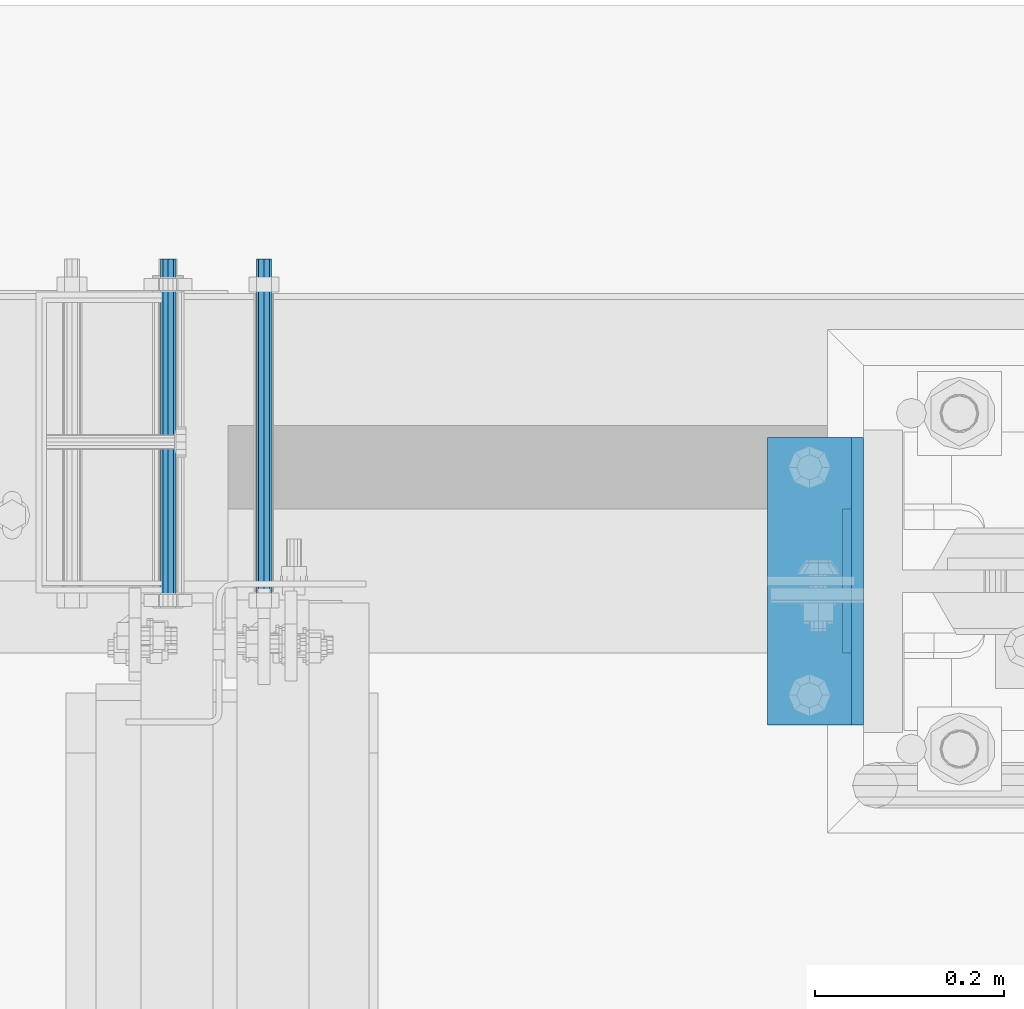
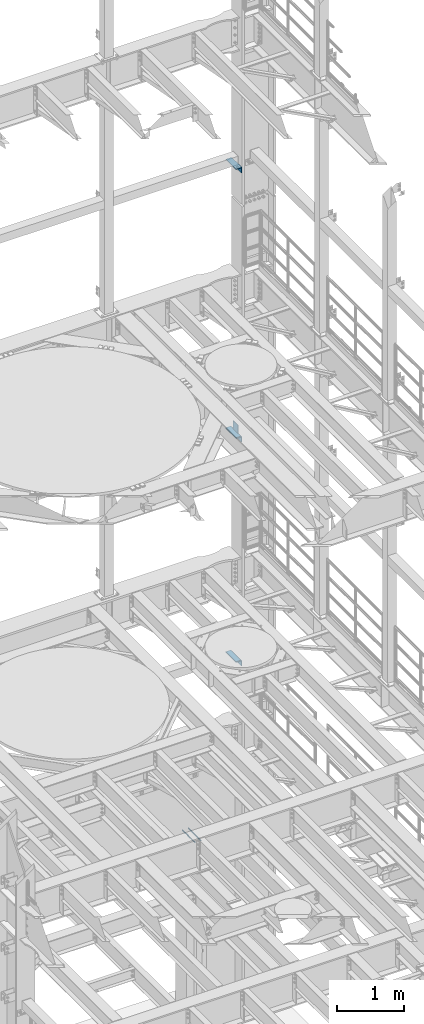
# One storey, part 1332 of 1876: 8 beams, 6 elements without a shape of their own.
"""IFC2X3 building model written with IfcOpenShell, lengths in millimetres."""

from ifc_helpers import new_model, si_unit, frame, origin_with_axes, place, context, subcontext, project, spatial, faceted_brep, material, type_object, element, aggregate, save


model = new_model("IFC2X3")

# Units and contexts
model_context = context("Model", 3, precision=1e-05, world=origin_with_axes())
body_context = subcontext(model_context, "Body", "Model", "MODEL_VIEW")
ifc_project = project(units=[si_unit("LENGTHUNIT", "METRE", prefix="MILLI"), si_unit("AREAUNIT", "SQUARE_METRE"), si_unit("VOLUMEUNIT", "CUBIC_METRE"), si_unit("MASSUNIT", "GRAM", prefix="KILO"), si_unit("TIMEUNIT", "SECOND"), si_unit("PLANEANGLEUNIT", "RADIAN"), si_unit("SOLIDANGLEUNIT", "STERADIAN"), si_unit("THERMODYNAMICTEMPERATUREUNIT", "DEGREE_CELSIUS"), si_unit("LUMINOUSINTENSITYUNIT", "LUMEN")], contexts=[model_context])

# Site, building, storey
site_placement = place(None, origin_with_axes())
site = spatial("IfcSite", under=ifc_project, at=site_placement, CompositionType="ELEMENT")
building_placement = place(site_placement, origin_with_axes())
building = spatial("IfcBuilding", under=site, at=building_placement, Name="Undefined", CompositionType="ELEMENT")
storey_placement = place(building_placement, origin_with_axes())
storey = spatial("IfcBuildingStorey", under=building, at=storey_placement, Name="Undefined", CompositionType="ELEMENT", Elevation=0.0)

# Assembly, beam
assembly_1_placement = place(storey_placement, origin_with_axes())
assembly_1 = element("IfcElementAssembly", 1, at=assembly_1_placement, inside=storey, Name="FRAME", AssemblyPlace="NOTDEFINED", PredefinedType="RIGID_FRAME")
ifc_material = material(Name="STEEL/A36")
beam_type_1 = type_object("IfcBeamType", PredefinedType="NOTDEFINED")
beam_1_placement = place(assembly_1_placement, frame((7310.4375, 13639.8, 10420.35), z_axis=(0.0, 0.0, -1.0), x_axis=(0.0, 1.0, 0.0)))
beam_1 = element("IfcBeam", 2, at=beam_1_placement, type_object=beam_type_1, material=ifc_material, Name="PLATE", context=body_context, shape_type="Brep", body=[
    faceted_brep([(0.0, 4.76249999999982, -76.1999999999998), (3.63797880709171e-12, 4.76249999999982, 76.1999969482422), (152.399993896484, 4.76250000000073, 76.1999969482422), (152.4, 4.76249999999982, -76.1999999999998), (3.63797880709171e-12, -4.76249999999982, 76.1999969482422), (152.399993896484, -4.76250000000073, 76.1999969482422), (0.0, -4.76249999999982, -76.1999999999998), (152.4, -4.76249999999982, -76.1999999999998)], [[[0, 1, 2, 3]], [[4, 5, 2, 1]], [[4, 6, 7, 5]], [[6, 0, 3, 7]], [[5, 7, 3, 2]], [[6, 4, 1, 0]]]),
])

assembly_2_placement = place(storey_placement, origin_with_axes())
assembly_2 = element("IfcElementAssembly", 3, at=assembly_2_placement, inside=storey, Name="FRAME", AssemblyPlace="NOTDEFINED", PredefinedType="RIGID_FRAME")
beam_type_2 = type_object("IfcBeamType", PredefinedType="NOTDEFINED")
beam_2_placement = place(assembly_2_placement, frame((7270.75, 13563.6, 6249.9875), z_axis=(-1.0, 0.0, 0.0), x_axis=(0.0, 1.0, 0.0)))
beam_2 = element("IfcBeam", 4, at=beam_2_placement, type_object=beam_type_2, material=ifc_material, Name="PLATE", context=body_context, shape_type="Brep", body=[
    faceted_brep([(0.0, 4.76250000000073, -44.4499999999998), (0.0, 4.76250000000073, 44.4499999999998), (304.799999999999, 4.76250000000073, 44.4499999999998), (304.799999999999, 4.76250000000073, -44.4499999999998), (0.0, -4.76250000000073, 44.4499999999998), (304.799999999999, -4.76250000000073, 44.4499999999998), (0.0, -4.76250000000073, -44.4499999999998), (304.799999999999, -4.76250000000073, -44.4499999999998)], [[[0, 1, 2, 3]], [[1, 4, 5, 2]], [[4, 6, 7, 5]], [[6, 0, 3, 7]], [[5, 7, 3, 2]], [[6, 4, 1, 0]]]),
])
aggregate(assembly_2, [beam_2])

# Beam
beam_3_placement = place(assembly_1_placement, frame((7270.75000000009, 13563.6, 10339.3875), z_axis=(-1.0, 0.0, 0.0), x_axis=(0.0, 1.0, 0.0)))
beam_3 = element("IfcBeam", 5, at=beam_3_placement, type_object=beam_type_2, material=ifc_material, Name="PLATE", context=body_context, shape_type="Brep", body=[
    faceted_brep([(0.0, 4.76250000000073, -44.4499999999998), (0.0, 4.76250000000073, 44.4499999999998), (304.799999999999, 4.76250000000073, 44.4499999999998), (304.799999999999, 4.76250000000073, -44.4499999999998), (0.0, -4.76250000000073, 44.4499999999998), (304.799999999999, -4.76250000000073, 44.4499999999998), (0.0, -4.76250000000073, -44.4499999999998), (304.799999999999, -4.76250000000073, -44.4499999999998)], [[[0, 1, 2, 3]], [[1, 4, 5, 2]], [[4, 6, 7, 5]], [[6, 0, 3, 7]], [[5, 7, 3, 2]], [[6, 4, 1, 0]]]),
])

aggregate(assembly_1, [beam_1, beam_3])

# Assembly, beam
assembly_3_placement = place(storey_placement, origin_with_axes())
assembly_3 = element("IfcElementAssembly", 6, at=assembly_3_placement, inside=storey, Name="COLUMN", AssemblyPlace="NOTDEFINED", PredefinedType="RIGID_FRAME")
beam_type_3 = type_object("IfcBeamType", Name="L4X4X3/8", PredefinedType="NOTDEFINED")
beam_4_placement = place(assembly_3_placement, frame((7277.1, 13868.4, 15198.725), z_axis=(-1.0, 0.0, 0.0), x_axis=(0.0, -1.0, 0.0)))
beam_4 = element("IfcBeam", 7, at=beam_4_placement, type_object=beam_type_3, material=ifc_material, Name="ANGLE", ObjectType="L4X4X3/8", context=body_context, shape_type="Brep", body=[
    faceted_brep([(0.0, 50.7999999999993, -50.8000000000002), (0.0, 50.7999999999993, 50.8000000000002), (304.799999999999, 50.7999999999993, 50.8000000000002), (304.799999999999, 50.7999999999993, -50.8000000000002), (0.0, 41.2750000000015, 50.8000000000002), (304.799999999999, 41.2750000000015, 50.8000000000002), (0.0, 41.2750000000015, -41.2749999999996), (304.799999999999, 41.2750000000015, -41.2749999999996), (0.0, -50.7999999999993, -41.2749999999996), (304.799999999999, -50.7999999999993, -41.2749999999996), (0.0, -50.7999999999993, -50.8000000000002), (304.799999999999, -50.7999999999993, -50.8000000000002)], [[[0, 1, 2, 3]], [[1, 4, 5, 2]], [[4, 6, 7, 5]], [[6, 8, 9, 7]], [[8, 10, 11, 9]], [[10, 0, 3, 11]], [[5, 7, 9, 11, 3, 2]], [[10, 8, 6, 4, 1, 0]]]),
])
aggregate(assembly_3, [beam_4])

# Assembly, beams
assembly_4_placement = place(storey_placement, origin_with_axes())
assembly_4 = element("IfcElementAssembly", 8, at=assembly_4_placement, inside=storey, Name="COLUMN", AssemblyPlace="NOTDEFINED", PredefinedType="RIGID_FRAME")
beam_5_placement = place(assembly_4_placement, frame((7277.1, 13868.4, 6194.425), z_axis=(-1.0, 0.0, 0.0), x_axis=(0.0, -1.0, 0.0)))
beam_5 = element("IfcBeam", 9, at=beam_5_placement, type_object=beam_type_3, material=ifc_material, Name="ANGLE", ObjectType="L4X4X3/8", context=body_context, shape_type="Brep", body=[
    faceted_brep([(0.0, 50.7999999999993, -50.8000000000002), (0.0, 50.7999999999993, 50.8000000000002), (304.799999999999, 50.7999999999993, 50.8000000000002), (304.799999999999, 50.7999999999993, -50.8000000000002), (0.0, 41.2750000000015, 50.8000000000002), (304.799999999999, 41.2750000000015, 50.8000000000002), (0.0, 41.2750000000015, -41.2749999999996), (304.799999999999, 41.2750000000015, -41.2749999999996), (0.0, -50.7999999999993, -41.2749999999996), (304.799999999999, -50.7999999999993, -41.2749999999996), (0.0, -50.7999999999993, -50.8000000000002), (304.799999999999, -50.7999999999993, -50.8000000000002)], [[[0, 1, 2, 3]], [[1, 4, 5, 2]], [[4, 6, 7, 5]], [[6, 8, 9, 7]], [[8, 10, 11, 9]], [[10, 0, 3, 11]], [[5, 7, 9, 11, 3, 2]], [[10, 8, 6, 4, 1, 0]]]),
])
beam_6_placement = place(assembly_4_placement, frame((7277.10000000009, 13868.4, 10283.825), z_axis=(-1.0, 0.0, 0.0), x_axis=(0.0, -1.0, 0.0)))
beam_6 = element("IfcBeam", 10, at=beam_6_placement, type_object=beam_type_3, material=ifc_material, Name="ANGLE", ObjectType="L4X4X3/8", context=body_context, shape_type="Brep", body=[
    faceted_brep([(0.0, 50.7999999999993, -50.8000000000002), (0.0, 50.7999999999993, 50.8000000000002), (304.799999999999, 50.7999999999993, 50.8000000000002), (304.799999999999, 50.7999999999993, -50.8000000000002), (0.0, 41.2750000000015, 50.8000000000002), (304.799999999999, 41.2750000000015, 50.8000000000002), (0.0, 41.2750000000015, -41.2749999999996), (304.799999999999, 41.2750000000015, -41.2749999999996), (0.0, -50.7999999999993, -41.2749999999996), (304.799999999999, -50.7999999999993, -41.2749999999996), (0.0, -50.7999999999993, -50.8000000000002), (304.799999999999, -50.7999999999993, -50.8000000000002)], [[[0, 1, 2, 3]], [[1, 4, 5, 2]], [[4, 6, 7, 5]], [[6, 8, 9, 7]], [[8, 10, 11, 9]], [[10, 0, 3, 11]], [[5, 7, 9, 11, 3, 2]], [[10, 8, 6, 4, 1, 0]]]),
])
aggregate(assembly_4, [beam_5, beam_6])

# Assembly, beam
assembly_5_placement = place(storey_placement, origin_with_axes())
assembly_5 = element("IfcElementAssembly", 11, at=assembly_5_placement, inside=storey, Name="ANCHOR_BOLT", AssemblyPlace="NOTDEFINED", PredefinedType="RIGID_FRAME")
beam_type_4 = type_object("IfcBeamType", PredefinedType="NOTDEFINED")
beam_7_placement = place(assembly_5_placement, frame((6692.91071748651, 14057.3124966791, 3103.56250152592), z_axis=(0.0, 0.0, 1.0), x_axis=(-2.91149999864615e-05, -0.999999999576158, 0.0)))
beam_7 = element("IfcBeam", 12, at=beam_7_placement, type_object=beam_type_4, material=ifc_material, Name="ANCHOR_BOLT", context=body_context, shape_type="Brep", body=[
    faceted_brep([(0.0, -7.9375, 0.0), (0.0, -5.61266007566822, -5.61266007566883), (369.887490732475, -5.61266007567792, -5.61266007566837), (369.887490732477, -7.93750000000978, 0.0), (0.0, 0.0, -7.9375), (369.88749073247, -9.54969436861575e-12, -7.9375), (0.0, 5.61266007566822, -5.61266007566883), (369.887490732464, 5.6126600756586, -5.61266007566837), (0.0, 7.9375, 0.0), (369.887490732463, 7.93749999999045, 0.0), (0.0, 5.61266007566822, 5.61266007566883), (369.887490732464, 5.6126600756586, 5.61266007566837), (0.0, 0.0, 7.9375), (369.88749073247, -9.54969436861575e-12, 7.9375), (0.0, -5.61266007566822, 5.61266007566883), (369.887490732475, -5.61266007567792, 5.61266007566837)], [[[0, 1, 2, 3]], [[1, 4, 5, 2]], [[4, 6, 7, 5]], [[6, 8, 9, 7]], [[8, 10, 11, 9]], [[10, 12, 13, 11]], [[12, 14, 15, 13]], [[14, 0, 3, 15]], [[5, 7, 9, 11, 13, 15, 3, 2]], [[14, 12, 10, 8, 6, 4, 1, 0]]]),
])
aggregate(assembly_5, [beam_7])

assembly_6_placement = place(storey_placement, origin_with_axes())
assembly_6 = element("IfcElementAssembly", 13, at=assembly_6_placement, inside=storey, Name="ANCHOR_BOLT", AssemblyPlace="NOTDEFINED", PredefinedType="RIGID_FRAME")
beam_8_placement = place(assembly_6_placement, frame((6591.31071748651, 14057.3124966791, 3103.56250152592), z_axis=(0.0, 0.0, 1.0), x_axis=(-2.91149999864615e-05, -0.999999999576158, 0.0)))
beam_8 = element("IfcBeam", 14, at=beam_8_placement, type_object=beam_type_4, material=ifc_material, Name="ANCHOR_BOLT", context=body_context, shape_type="Brep", body=[
    faceted_brep([(0.0, -7.9375, 0.0), (0.0, -5.61266007566822, -5.61266007566883), (369.887490732475, -5.61266007567792, -5.61266007566837), (369.887490732477, -7.93750000000978, 0.0), (0.0, 0.0, -7.9375), (369.88749073247, -9.54969436861575e-12, -7.9375), (0.0, 5.61266007566822, -5.61266007566883), (369.887490732464, 5.6126600756586, -5.61266007566837), (0.0, 7.9375, 0.0), (369.887490732463, 7.93749999999045, 0.0), (0.0, 5.61266007566822, 5.61266007566883), (369.887490732464, 5.6126600756586, 5.61266007566837), (0.0, 0.0, 7.9375), (369.88749073247, -9.54969436861575e-12, 7.9375), (0.0, -5.61266007566822, 5.61266007566883), (369.887490732475, -5.61266007567792, 5.61266007566837)], [[[0, 1, 2, 3]], [[1, 4, 5, 2]], [[4, 6, 7, 5]], [[6, 8, 9, 7]], [[8, 10, 11, 9]], [[10, 12, 13, 11]], [[12, 14, 15, 13]], [[14, 0, 3, 15]], [[5, 7, 9, 11, 13, 15, 3, 2]], [[14, 12, 10, 8, 6, 4, 1, 0]]]),
])
aggregate(assembly_6, [beam_8])

save(model, "model.ifc")
